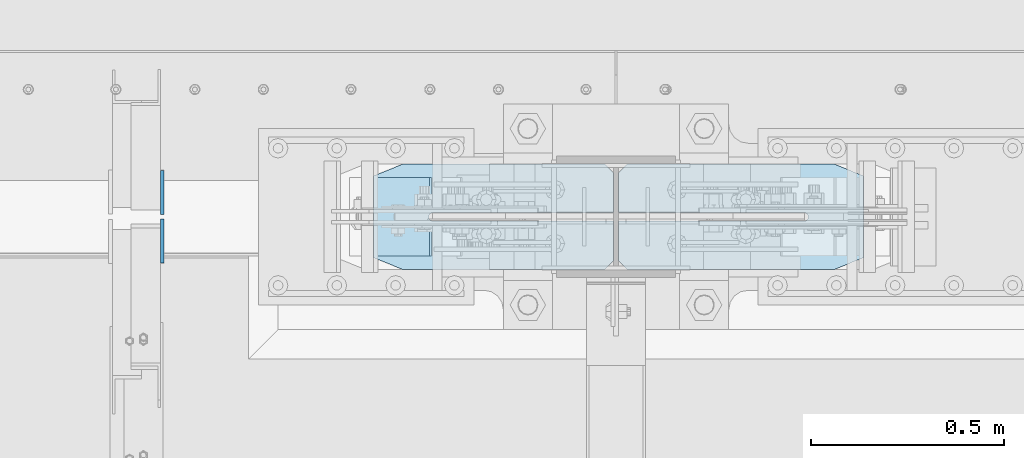
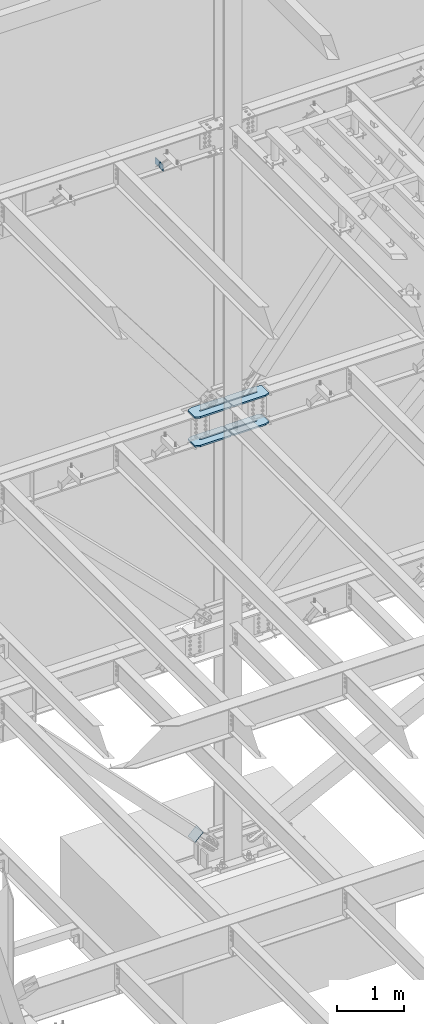
# One storey, part 1071 of 1179: 7 plates, 3 elements without a shape of their own.
"""IFC2X3 building model written with IfcOpenShell, lengths in millimetres."""

from ifc_helpers import new_model, si_unit, frame, origin_with_axes, place, context, subcontext, project, spatial, faceted_brep, material, type_object, element, aggregate, save


model = new_model("IFC2X3")

# Units and contexts
model_context = context("Model", 3, precision=1e-05, world=origin_with_axes())
body_context = subcontext(model_context, "Body", "Model", "MODEL_VIEW")
ifc_project = project(units=[si_unit("LENGTHUNIT", "METRE", prefix="MILLI"), si_unit("AREAUNIT", "SQUARE_METRE"), si_unit("VOLUMEUNIT", "CUBIC_METRE"), si_unit("MASSUNIT", "GRAM", prefix="KILO"), si_unit("TIMEUNIT", "SECOND"), si_unit("PLANEANGLEUNIT", "RADIAN"), si_unit("SOLIDANGLEUNIT", "STERADIAN"), si_unit("THERMODYNAMICTEMPERATUREUNIT", "DEGREE_CELSIUS"), si_unit("LUMINOUSINTENSITYUNIT", "LUMEN")], contexts=[model_context])

# Site, building, storey
site_placement = place(None, origin_with_axes())
site = spatial("IfcSite", under=ifc_project, at=site_placement, CompositionType="ELEMENT")
building_placement = place(site_placement, origin_with_axes())
building = spatial("IfcBuilding", under=site, at=building_placement, Name="Undefined", CompositionType="ELEMENT")
storey_placement = place(building_placement, origin_with_axes())
storey = spatial("IfcBuildingStorey", under=building, at=storey_placement, Name="Undefined", CompositionType="ELEMENT", Elevation=0.0)

# Assembly, plate
assembly_1_placement = place(storey_placement, origin_with_axes())
assembly_1 = element("IfcElementAssembly", 1, at=assembly_1_placement, inside=storey, Name="Plate", AssemblyPlace="NOTDEFINED", PredefinedType="RIGID_FRAME")
ifc_material_1 = material(Name="STEEL/A36")
plate_type_1 = type_object("IfcPlateType", PredefinedType="NOTDEFINED")
plate_1_placement = place(assembly_1_placement, frame((7653.65937875758, 41300.4, 283.975750075679), z_axis=(0.717593116036187, 0.0, 0.696462576035121), x_axis=(0.0, -1.0, 0.0)))
plate_1 = element("IfcPlate", 2, at=plate_1_placement, type_object=plate_type_1, material=ifc_material_1, Name="Plate", context=body_context, shape_type="Brep", body=[
    faceted_brep([(0.0, -3.17500000000109, 0.0), (0.0, -3.17500000000291, 203.200000000368), (0.0, 3.17499999998836, 203.200000000361), (0.0, 3.17500000000109, 7.27595761418343e-12), (203.199999999997, -3.17500000000291, 203.200000000368), (203.199999999997, 3.17499999998836, 203.200000000361), (203.199999999997, -3.17499999999927, 3.63797880709171e-12), (203.199999999997, 3.17499999999382, -3.63797880709171e-12)], [[[0, 1, 2, 3]], [[1, 4, 5, 2]], [[4, 6, 7, 5]], [[6, 0, 3, 7]], [[5, 7, 3, 2]], [[6, 4, 1, 0]]]),
])
aggregate(assembly_1, [plate_1])

# Assembly, plates
assembly_2_placement = place(storey_placement, origin_with_axes())
assembly_2 = element("IfcElementAssembly", 3, at=assembly_2_placement, inside=storey, Name="COLUMN", AssemblyPlace="NOTDEFINED", PredefinedType="RIGID_FRAME")
ifc_material_2 = material(Name="STEEL/A572-GR.50")
plate_type_2 = type_object("IfcPlateType", PredefinedType="NOTDEFINED")
plate_2_placement = place(assembly_2_placement, frame((7651.94016895385, 41335.1078456819, 7478.7125), z_axis=(0.0, -1.0, 0.0), x_axis=(1.0, 0.0, 0.0)))
plate_2 = element("IfcPlate", 4, at=plate_2_placement, type_object=plate_type_2, material=ifc_material_2, Name="PLATE", context=body_context, shape_type="Brep", body=[
    faceted_brep([(0.0, -14.2875000000004, 30.1625003814697), (0.0, -14.2875000000004, 242.453264224023), (0.0, 14.2875000000004, 242.453264224023), (0.0, 14.2875000000004, 30.1625003814697), (74.6125030517578, -14.2875000000004, 272.615764605493), (74.6125030517578, 14.2875000000004, 272.615764605493), (599.884830625004, -14.2875000000004, 272.615764605493), (599.884830625004, 14.2875000000004, 272.615764605493), (622.109831006474, -14.2875000000004, 250.390764224023), (622.109831006474, 14.2875000000004, 250.390764224023), (622.109831006474, -14.2875000000004, 147.202764605485), (622.109831006474, 14.2875000000004, 147.202764605485), (153.997588991463, -14.2875000000004, 147.62774786006), (153.997588991463, 14.2875000000004, 147.62774786006), (149.741922132855, -14.2875000000004, 146.784756922243), (149.741922132855, 14.2875000000004, 146.784756922243), (146.133343781504, -14.2875000000004, 144.376542559927), (146.133343781504, 14.2875000000004, 144.376542559927), (143.721854306888, -14.2875000000004, 140.770152031087), (143.721854306888, 14.2875000000004, 140.770152031087), (142.875000142223, -14.2875000000004, 136.525345872607), (142.875000142223, 14.2875000000004, 136.525345872607), (143.720888851711, -14.2875000000004, 132.272776157457), (143.720888851711, 14.2875000000004, 132.272776157457), (146.129776092153, -14.2875000000004, 128.667621631801), (146.129776092153, 14.2875000000004, 128.667621631801), (149.734930617809, -14.2875000000004, 126.258734391362), (149.734930617809, 14.2875000000004, 126.258734391362), (153.987500332958, -14.2875000000004, 125.412845681873), (153.987500332958, 14.2875000000004, 125.412845681873), (622.109831148695, -14.2875000000004, 125.412845681873), (622.109831148695, 14.2875000000004, 125.412845681873), (622.109831031677, -14.2875000000004, 22.2250003814697), (622.109831031677, 14.2875000000004, 22.2250003814697), (599.884830625004, -14.2875000000004, 0.0), (599.884830625004, 14.2875000000004, 0.0), (74.6125030517578, -14.2875000000004, 0.0), (74.6125030517578, 14.2875000000004, 0.0)], [[[0, 1, 2, 3]], [[1, 4, 5, 2]], [[4, 6, 7, 5]], [[6, 8, 9, 7]], [[8, 10, 11, 9]], [[10, 12, 13, 11]], [[12, 14, 15, 13]], [[14, 16, 17, 15]], [[16, 18, 19, 17]], [[18, 20, 21, 19]], [[20, 22, 23, 21]], [[22, 24, 25, 23]], [[24, 26, 27, 25]], [[26, 28, 29, 27]], [[28, 30, 31, 29]], [[30, 32, 33, 31]], [[32, 34, 35, 33]], [[34, 36, 37, 35]], [[36, 0, 3, 37]], [[5, 7, 9, 11, 13, 15, 17, 19, 21, 23, 25, 27, 29, 31, 33, 35, 37, 3, 2]], [[36, 34, 32, 30, 28, 26, 24, 22, 20, 18, 16, 14, 12, 10, 8, 6, 4, 1, 0]]]),
])
plate_3_placement = place(assembly_2_placement, frame((7651.94016895385, 41335.1078456819, 7999.4125), z_axis=(0.0, -1.0, 0.0), x_axis=(1.0, 0.0, 0.0)))
plate_3 = element("IfcPlate", 5, at=plate_3_placement, type_object=plate_type_2, material=ifc_material_2, Name="PLATE", context=body_context, shape_type="Brep", body=[
    faceted_brep([(0.0, -14.2875000000004, 30.1625003814697), (0.0, -14.2875000000004, 242.453264224023), (0.0, 14.2875000000004, 242.453264224023), (0.0, 14.2875000000004, 30.1625003814697), (74.6125030517578, -14.2875000000004, 272.615764605493), (74.6125030517578, 14.2875000000004, 272.615764605493), (599.884830625004, -14.2875000000004, 272.615764605493), (599.884830625004, 14.2875000000004, 272.615764605493), (622.109831006474, -14.2875000000004, 250.390764224023), (622.109831006474, 14.2875000000004, 250.390764224023), (622.109831006474, -14.2875000000004, 147.202764605485), (622.109831006474, 14.2875000000004, 147.202764605485), (153.997588991463, -14.2875000000004, 147.62774786006), (153.997588991463, 14.2875000000004, 147.62774786006), (149.741922132855, -14.2875000000004, 146.784756922243), (149.741922132855, 14.2875000000004, 146.784756922243), (146.133343781504, -14.2875000000004, 144.376542559927), (146.133343781504, 14.2875000000004, 144.376542559927), (143.721854306888, -14.2875000000004, 140.770152031087), (143.721854306888, 14.2875000000004, 140.770152031087), (142.875000142223, -14.2875000000004, 136.525345872607), (142.875000142223, 14.2875000000004, 136.525345872607), (143.720888851711, -14.2875000000004, 132.272776157457), (143.720888851711, 14.2875000000004, 132.272776157457), (146.129776092153, -14.2875000000004, 128.667621631801), (146.129776092153, 14.2875000000004, 128.667621631801), (149.734930617809, -14.2875000000004, 126.258734391362), (149.734930617809, 14.2875000000004, 126.258734391362), (153.987500332958, -14.2875000000004, 125.412845681873), (153.987500332958, 14.2875000000004, 125.412845681873), (622.109831148695, -14.2875000000004, 125.412845681873), (622.109831148695, 14.2875000000004, 125.412845681873), (622.109831031677, -14.2875000000004, 22.2250003814697), (622.109831031677, 14.2875000000004, 22.2250003814697), (599.884830625004, -14.2875000000004, 0.0), (599.884830625004, 14.2875000000004, 0.0), (74.6125030517578, -14.2875000000004, 0.0), (74.6125030517578, 14.2875000000004, 0.0)], [[[0, 1, 2, 3]], [[1, 4, 5, 2]], [[4, 6, 7, 5]], [[6, 8, 9, 7]], [[8, 10, 11, 9]], [[10, 12, 13, 11]], [[12, 14, 15, 13]], [[14, 16, 17, 15]], [[16, 18, 19, 17]], [[18, 20, 21, 19]], [[20, 22, 23, 21]], [[22, 24, 25, 23]], [[24, 26, 27, 25]], [[26, 28, 29, 27]], [[28, 30, 31, 29]], [[30, 32, 33, 31]], [[32, 34, 35, 33]], [[34, 36, 37, 35]], [[36, 0, 3, 37]], [[5, 7, 9, 11, 13, 15, 17, 19, 21, 23, 25, 27, 29, 31, 33, 35, 37, 3, 2]], [[36, 34, 32, 30, 28, 26, 24, 22, 20, 18, 16, 14, 12, 10, 8, 6, 4, 1, 0]]]),
])
plate_4_placement = place(assembly_2_placement, frame((8922.04640199402, 41335.1078456819, 7478.71299953461), z_axis=(0.0, -1.0, 0.0), x_axis=(-1.0, 0.0, 0.0)))
plate_4 = element("IfcPlate", 6, at=plate_4_placement, type_object=plate_type_2, material=ifc_material_2, Name="PLATE", context=body_context, shape_type="Brep", body=[
    faceted_brep([(0.0, -14.2875000000004, 30.1625003814697), (0.0, -14.2875000000004, 242.453264224023), (0.0, 14.2875000000004, 242.453264224023), (0.0, 14.2875000000004, 30.1625003814697), (74.6125030517578, -14.2875000000004, 272.615764605493), (74.6125030517578, 14.2875000000004, 272.615764605493), (613.071401470328, -14.2875000000004, 272.615764605493), (613.071401470328, 14.2875000000004, 272.615764605493), (635.296401851798, -14.2875000000004, 250.390764224023), (635.296401851798, 14.2875000000004, 250.390764224023), (635.296401851798, -14.2875000000004, 147.202764605485), (635.296401851798, 14.2875000000004, 147.202764605485), (153.997318827118, -14.2875000000004, 147.628018508702), (153.997318827118, 14.2875000000004, 147.628018508702), (149.741734881249, -14.2875000000004, 146.784949914079), (149.741734881249, 14.2875000000004, 146.784949914079), (146.133248221176, -14.2875000000004, 144.376717491818), (146.133248221176, 14.2875000000004, 144.376717491818), (143.721828446049, -14.2875000000004, 140.770360043687), (143.721828446049, 14.2875000000004, 140.770360043687), (142.875000142223, -14.2875000000004, 136.525345872607), (142.875000142223, 14.2875000000004, 136.525345872607), (143.720888851711, -14.2875000000004, 132.272776157457), (143.720888851711, 14.2875000000004, 132.272776157457), (146.129776092153, -14.2875000000004, 128.667621631801), (146.129776092153, 14.2875000000004, 128.667621631801), (149.734930617809, -14.2875000000004, 126.258734391362), (149.734930617809, 14.2875000000004, 126.258734391362), (153.987500332958, -14.2875000000004, 125.412845681873), (153.987500332958, 14.2875000000004, 125.412845681873), (635.296401994021, -14.2875000000004, 125.412845681873), (635.296401994021, 14.2875000000004, 125.412845681873), (635.296401877002, -14.2875000000004, 22.2250003814697), (635.296401877002, 14.2875000000004, 22.2250003814697), (613.071401470328, -14.2875000000004, 0.0), (613.071401470328, 14.2875000000004, 0.0), (74.6125030517578, -14.2875000000004, 0.0), (74.6125030517578, 14.2875000000004, 0.0)], [[[0, 1, 2, 3]], [[1, 4, 5, 2]], [[4, 6, 7, 5]], [[6, 8, 9, 7]], [[8, 10, 11, 9]], [[10, 12, 13, 11]], [[12, 14, 15, 13]], [[14, 16, 17, 15]], [[16, 18, 19, 17]], [[18, 20, 21, 19]], [[20, 22, 23, 21]], [[22, 24, 25, 23]], [[24, 26, 27, 25]], [[26, 28, 29, 27]], [[28, 30, 31, 29]], [[30, 32, 33, 31]], [[32, 34, 35, 33]], [[34, 36, 37, 35]], [[36, 0, 3, 37]], [[5, 7, 9, 11, 13, 15, 17, 19, 21, 23, 25, 27, 29, 31, 33, 35, 37, 3, 2]], [[36, 34, 32, 30, 28, 26, 24, 22, 20, 18, 16, 14, 12, 10, 8, 6, 4, 1, 0]]]),
])
plate_5_placement = place(assembly_2_placement, frame((8922.04640199402, 41335.1078456819, 7999.4125), z_axis=(0.0, -1.0, 0.0), x_axis=(-1.0, 0.0, 0.0)))
plate_5 = element("IfcPlate", 7, at=plate_5_placement, type_object=plate_type_2, material=ifc_material_2, Name="PLATE", context=body_context, shape_type="Brep", body=[
    faceted_brep([(0.0, -14.2875000000004, 30.1625003814697), (0.0, -14.2875000000004, 242.453264224023), (0.0, 14.2875000000004, 242.453264224023), (0.0, 14.2875000000004, 30.1625003814697), (74.6125030517578, -14.2875000000004, 272.615764605493), (74.6125030517578, 14.2875000000004, 272.615764605493), (613.071401470328, -14.2875000000004, 272.615764605493), (613.071401470328, 14.2875000000004, 272.615764605493), (635.296401851798, -14.2875000000004, 250.390764224023), (635.296401851798, 14.2875000000004, 250.390764224023), (635.296401851798, -14.2875000000004, 147.202764605485), (635.296401851798, 14.2875000000004, 147.202764605485), (153.997318827118, -14.2875000000004, 147.628018508702), (153.997318827118, 14.2875000000004, 147.628018508702), (149.741734881249, -14.2875000000004, 146.784949914079), (149.741734881249, 14.2875000000004, 146.784949914079), (146.133248221176, -14.2875000000004, 144.376717491818), (146.133248221176, 14.2875000000004, 144.376717491818), (143.721828446049, -14.2875000000004, 140.770360043687), (143.721828446049, 14.2875000000004, 140.770360043687), (142.875000142223, -14.2875000000004, 136.525345872607), (142.875000142223, 14.2875000000004, 136.525345872607), (143.720888851711, -14.2875000000004, 132.272776157457), (143.720888851711, 14.2875000000004, 132.272776157457), (146.129776092153, -14.2875000000004, 128.667621631801), (146.129776092153, 14.2875000000004, 128.667621631801), (149.734930617809, -14.2875000000004, 126.258734391362), (149.734930617809, 14.2875000000004, 126.258734391362), (153.987500332958, -14.2875000000004, 125.412845681873), (153.987500332958, 14.2875000000004, 125.412845681873), (635.296401994021, -14.2875000000004, 125.412845681873), (635.296401994021, 14.2875000000004, 125.412845681873), (635.296401877002, -14.2875000000004, 22.2250003814697), (635.296401877002, 14.2875000000004, 22.2250003814697), (613.071401470328, -14.2875000000004, 0.0), (613.071401470328, 14.2875000000004, 0.0), (74.6125030517578, -14.2875000000004, 0.0), (74.6125030517578, 14.2875000000004, 0.0)], [[[0, 1, 2, 3]], [[1, 4, 5, 2]], [[4, 6, 7, 5]], [[6, 8, 9, 7]], [[8, 10, 11, 9]], [[10, 12, 13, 11]], [[12, 14, 15, 13]], [[14, 16, 17, 15]], [[16, 18, 19, 17]], [[18, 20, 21, 19]], [[20, 22, 23, 21]], [[22, 24, 25, 23]], [[24, 26, 27, 25]], [[26, 28, 29, 27]], [[28, 30, 31, 29]], [[30, 32, 33, 31]], [[32, 34, 35, 33]], [[34, 36, 37, 35]], [[36, 0, 3, 37]], [[5, 7, 9, 11, 13, 15, 17, 19, 21, 23, 25, 27, 29, 31, 33, 35, 37, 3, 2]], [[36, 34, 32, 30, 28, 26, 24, 22, 20, 18, 16, 14, 12, 10, 8, 6, 4, 1, 0]]]),
])
aggregate(assembly_2, [plate_2, plate_3, plate_4, plate_5])

assembly_3_placement = place(storey_placement, origin_with_axes())
assembly_3 = element("IfcElementAssembly", 8, at=assembly_3_placement, inside=storey, Name="BEAM", AssemblyPlace="NOTDEFINED", PredefinedType="RIGID_FRAME")
plate_type_3 = type_object("IfcPlateType", PredefinedType="NOTDEFINED")
plate_6_placement = place(assembly_3_placement, frame((7104.06250000001, 41193.24375, 12690.4749987075), z_axis=(0.0, -0.707106781186506, 0.707106781186589), x_axis=(0.0, -0.70710678118659, -0.707106781186505)))
plate_6 = element("IfcPlate", 9, at=plate_6_placement, type_object=plate_type_3, material=ifc_material_1, Name="PLATE", context=body_context, shape_type="Brep", body=[
    faceted_brep([(0.0, -4.76249999999709, 0.0), (-67.3519210815575, -4.76250000000073, 67.3519210815502), (-67.3519210815575, 4.76250000000073, 67.3519210815502), (0.0, 4.76249999999709, 0.0), (13.4703845975746, -4.76250000000073, 148.174224853334), (13.4703845975746, 4.76250000000073, 148.174224853334), (94.2926864622132, -4.76250000000073, 67.3519210813465), (94.2926864622132, 4.76250000000073, 67.3519210813465), (26.9407683631525, -4.76249999999709, -6.18456397205591e-11), (26.9407683631525, 4.76249999999709, -6.18456397205591e-11)], [[[0, 1, 2, 3]], [[1, 4, 5, 2]], [[4, 6, 7, 5]], [[6, 8, 9, 7]], [[8, 0, 3, 9]], [[5, 7, 9, 3, 2]], [[8, 6, 4, 1, 0]]]),
])
plate_7_placement = place(assembly_3_placement, frame((7104.06250000001, 41204.35625, 12690.4749987075), z_axis=(0.0, 0.707106781186542, 0.707106781186553), x_axis=(0.0, 0.707106781186553, -0.707106781186542)))
plate_7 = element("IfcPlate", 10, at=plate_7_placement, type_object=plate_type_3, material=ifc_material_1, Name="PLATE", context=body_context, shape_type="Brep", body=[
    faceted_brep([(0.0, -4.76249999999709, 0.0), (-67.3519210815575, -4.76250000000073, 67.3519210815502), (-67.3519210815575, 4.76250000000073, 67.3519210815502), (0.0, 4.76249999999709, 0.0), (13.4703845975746, -4.76250000000073, 148.174224853334), (13.4703845975746, 4.76250000000073, 148.174224853334), (94.2926864622132, -4.76250000000073, 67.3519210813465), (94.2926864622132, 4.76250000000073, 67.3519210813465), (26.9407683631525, -4.76249999999709, -6.18456397205591e-11), (26.9407683631525, 4.76249999999709, -6.18456397205591e-11)], [[[0, 1, 2, 3]], [[1, 4, 5, 2]], [[4, 6, 7, 5]], [[6, 8, 9, 7]], [[8, 0, 3, 9]], [[5, 7, 9, 3, 2]], [[8, 6, 4, 1, 0]]]),
])
aggregate(assembly_3, [plate_6, plate_7])

save(model, "model.ifc")
